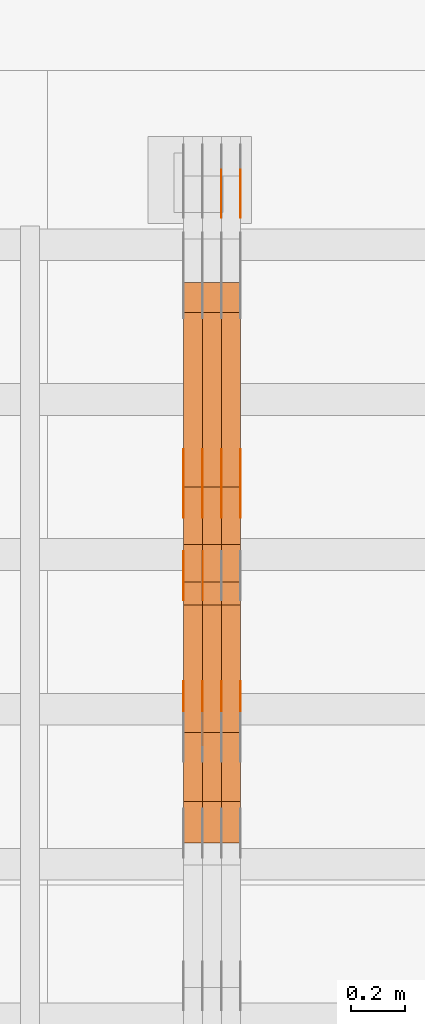
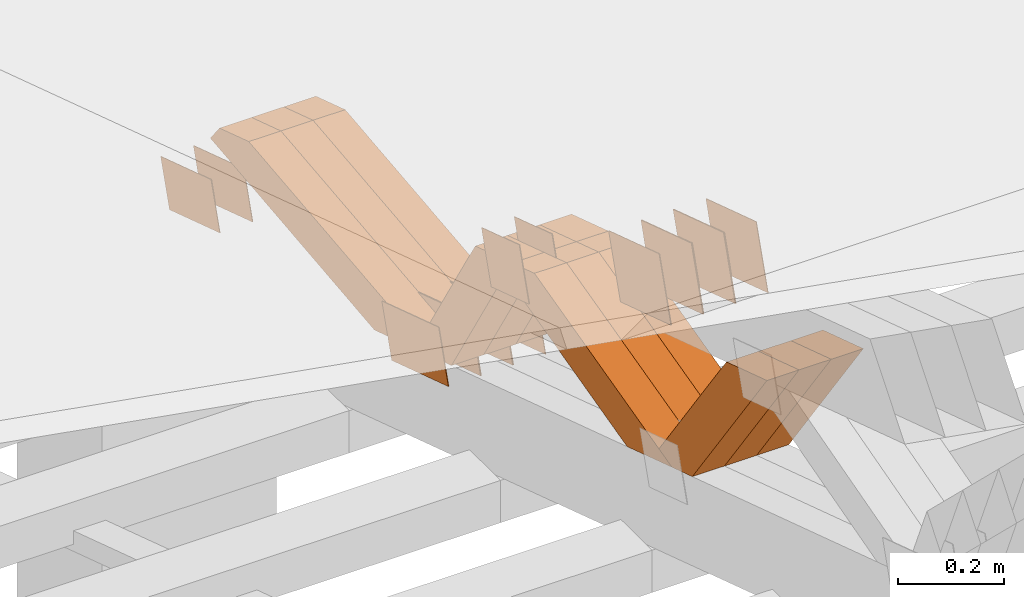
# One storey, part 202 of 385: 28 proxies.
"""IFC2X3 building model written with IfcOpenShell, lengths in millimetres."""

from ifc_helpers import new_model, entity, si_unit, converted_unit, derived_unit, direction, frame, origin, place, context, subcontext, project, spatial, polyline, outline, extrude, source, transform, mapped, material, type_object, type_shapes, element, save


model = new_model("IFC2X3")

# Units and contexts
model_context = context("Model", 3, precision=0.01, world=origin(), true_north=direction((6.12303176911189e-17, 1.0)))
body_context = subcontext(model_context, "Body", "Model", "MODEL_VIEW")
ifc_project = project(units=[si_unit("LENGTHUNIT", "METRE", prefix="MILLI"), si_unit("AREAUNIT", "SQUARE_METRE"), si_unit("VOLUMEUNIT", "CUBIC_METRE"), converted_unit("PLANEANGLEUNIT", "DEGREE", entity("IfcRatioMeasure", 0.0174532925199433), si_unit("PLANEANGLEUNIT", "RADIAN"), dimensions=[0, 0, 0, 0, 0, 0, 0]), si_unit("MASSUNIT", "GRAM", prefix="KILO"), derived_unit("MASSDENSITYUNIT", [(si_unit("MASSUNIT", "GRAM", prefix="KILO"), 1), (si_unit("LENGTHUNIT", "METRE"), -3)]), si_unit("TIMEUNIT", "SECOND"), si_unit("FREQUENCYUNIT", "HERTZ"), si_unit("THERMODYNAMICTEMPERATUREUNIT", "DEGREE_CELSIUS"), derived_unit("THERMALTRANSMITTANCEUNIT", [(si_unit("MASSUNIT", "GRAM", prefix="KILO"), 1), (si_unit("THERMODYNAMICTEMPERATUREUNIT", "KELVIN"), -1), (si_unit("TIMEUNIT", "SECOND"), -3)]), derived_unit("VOLUMETRICFLOWRATEUNIT", [(si_unit("LENGTHUNIT", "METRE"), 3), (si_unit("TIMEUNIT", "SECOND"), -1)]), si_unit("ELECTRICCURRENTUNIT", "AMPERE"), si_unit("ELECTRICVOLTAGEUNIT", "VOLT"), si_unit("POWERUNIT", "WATT"), si_unit("FORCEUNIT", "NEWTON", prefix="KILO"), si_unit("ILLUMINANCEUNIT", "LUX"), si_unit("LUMINOUSFLUXUNIT", "LUMEN"), si_unit("LUMINOUSINTENSITYUNIT", "CANDELA"), derived_unit("USERDEFINED", [(si_unit("MASSUNIT", "GRAM", prefix="KILO"), -1), (si_unit("LENGTHUNIT", "METRE"), -2), (si_unit("TIMEUNIT", "SECOND"), 3), (si_unit("LUMINOUSFLUXUNIT", "LUMEN"), 1)]), derived_unit("LINEARVELOCITYUNIT", [(si_unit("LENGTHUNIT", "METRE"), 1), (si_unit("TIMEUNIT", "SECOND"), -1)]), si_unit("PRESSUREUNIT", "PASCAL"), derived_unit("USERDEFINED", [(si_unit("LENGTHUNIT", "METRE"), -2), (si_unit("MASSUNIT", "GRAM", prefix="KILO"), 1), (si_unit("TIMEUNIT", "SECOND"), -2)])], contexts=[model_context])

# Site, building, storey
site_placement = place(None, origin())
site = spatial("IfcSite", under=ifc_project, at=site_placement, CompositionType="ELEMENT")
building_placement = place(site_placement, origin())
building = spatial("IfcBuilding", under=site, at=building_placement, CompositionType="ELEMENT")
storey_placement = place(building_placement, origin())
storey = spatial("IfcBuildingStorey", under=building, at=storey_placement, Name="Default", CompositionType="ELEMENT", Elevation=0.0)

# Proxies
ifc_material_1 = material(Name="IfcSurfaceStyle #137198")
building_element_proxy_type_1 = type_object("IfcBuildingElementProxyType", PredefinedType="NOTDEFINED", material=ifc_material_1)
shared_shape_1 = source(origin(), body_context, "Body", "SweptSolid", [
    extrude(outline(polyline([(-100.000024997547, -54.0000105875654), (100.000088940899, -54.0000105875654), (99.9999100805868, 54.0000105875654), (-99.9999740239394, 54.0000105875654), (-100.000024997547, -54.0000105875654)])), frame((100.000088940899, 54.0000474633838, 0.0), z_axis=(0.0, 0.0, 1.0), x_axis=(-1.0, 0.0, 0.0)), (0.0, 0.0, 1.0), 1.3),
])
type_shapes(building_element_proxy_type_1, [shared_shape_1])
proxy_1_placement = place(building_placement, frame((9386.29999999998, 26390.6212638563, 73.3227520411355), z_axis=(-1.0, 0.0, 0.0), x_axis=(0.0, -0.951056516295124, 0.309016994375039)))
element("IfcBuildingElementProxy", 1, at=proxy_1_placement, inside=storey, type_object=building_element_proxy_type_1, material=ifc_material_1, context=body_context, shape_type="MappedRepresentation", body=[
    mapped(shared_shape_1, transform((0.0, 0.0, 0.0), scale=1.0)),
])
ifc_material_2 = material(Name="IfcSurfaceStyle #137141")
building_element_proxy_type_2 = type_object("IfcBuildingElementProxyType", PredefinedType="NOTDEFINED", material=ifc_material_2)
shared_shape_2 = source(origin(), body_context, "Body", "SweptSolid", [
    extrude(outline(polyline([(-100.000024997547, -54.0000105875654), (100.000088940899, -54.0000105875654), (99.9999100805868, 54.0000105875654), (-99.9999740239394, 54.0000105875654), (-100.000024997547, -54.0000105875654)])), frame((100.000088940899, 54.0000474633838, 0.0), z_axis=(0.0, 0.0, 1.0), x_axis=(-1.0, 0.0, 0.0)), (0.0, 0.0, 1.0), 1.3),
])
type_shapes(building_element_proxy_type_2, [shared_shape_2])
proxy_2_placement = place(building_placement, frame((9315.0, 26390.6212638563, 73.3227520411355), z_axis=(-1.0, 0.0, 0.0), x_axis=(0.0, -0.951056516295124, 0.309016994375039)))
element("IfcBuildingElementProxy", 2, at=proxy_2_placement, inside=storey, type_object=building_element_proxy_type_2, material=ifc_material_2, context=body_context, shape_type="MappedRepresentation", body=[
    mapped(shared_shape_2, transform((0.0, 0.0, 0.0), scale=1.0)),
])
ifc_material_3 = material(Name="IfcSurfaceStyle #125342")
building_element_proxy_type_3 = type_object("IfcBuildingElementProxyType", PredefinedType="NOTDEFINED", material=ifc_material_3)
shared_shape_3 = source(origin(), body_context, "Body", "SweptSolid", [
    extrude(outline(polyline([(-75.0001163267648, -60.0000309352964), (75.0001029049313, -60.0000309352964), (75.0001068963143, 60.0000309352964), (-75.0000934744807, 60.0000309352964), (-75.0001163267648, -60.0000309352964)])), frame((75.0001143227305, 60.0000309352964, 0.0), z_axis=(0.0, 0.0, 1.0), x_axis=(-1.0, 0.0, 0.0)), (0.0, 0.0, 1.0), 1.29999999999999),
])
type_shapes(building_element_proxy_type_3, [shared_shape_3])
proxy_3_placement = place(building_placement, frame((9246.29999999998, 24935.0160969462, 827.753587802763), z_axis=(-1.0, 0.0, 0.0), x_axis=(0.0, -0.951056516295154, 0.309016994374948)))
element("IfcBuildingElementProxy", 3, at=proxy_3_placement, inside=storey, type_object=building_element_proxy_type_3, material=ifc_material_3, context=body_context, shape_type="MappedRepresentation", body=[
    mapped(shared_shape_3, transform((0.0, 0.0, 0.0), scale=1.0)),
])
ifc_material_4 = material(Name="IfcSurfaceStyle #125285")
building_element_proxy_type_4 = type_object("IfcBuildingElementProxyType", PredefinedType="NOTDEFINED", material=ifc_material_4)
shared_shape_4 = source(origin(), body_context, "Body", "SweptSolid", [
    extrude(outline(polyline([(-75.0001163267648, -60.0000309352964), (75.0001029049313, -60.0000309352964), (75.0001068963143, 60.0000309352964), (-75.0000934744807, 60.0000309352964), (-75.0001163267648, -60.0000309352964)])), frame((75.0001143227305, 60.0000309352964, 0.0), z_axis=(0.0, 0.0, 1.0), x_axis=(-1.0, 0.0, 0.0)), (0.0, 0.0, 1.0), 1.29999999999999),
])
type_shapes(building_element_proxy_type_4, [shared_shape_4])
proxy_4_placement = place(building_placement, frame((9175.0, 24935.0160969462, 827.753587802763), z_axis=(-1.0, 0.0, 0.0), x_axis=(0.0, -0.951056516295154, 0.309016994374948)))
element("IfcBuildingElementProxy", 4, at=proxy_4_placement, inside=storey, type_object=building_element_proxy_type_4, material=ifc_material_4, context=body_context, shape_type="MappedRepresentation", body=[
    mapped(shared_shape_4, transform((0.0, 0.0, 0.0), scale=1.0)),
])
ifc_material_5 = material(Name="IfcSurfaceStyle #125228")
building_element_proxy_type_5 = type_object("IfcBuildingElementProxyType", PredefinedType="NOTDEFINED", material=ifc_material_5)
shared_shape_5 = source(origin(), body_context, "Body", "SweptSolid", [
    extrude(outline(polyline([(-112.50003853564, -60.0000121429077), (112.50002982902, -60.0000121429077), (112.500043250865, 60.0000121429077), (-112.500034544245, 60.0000121429077), (-112.50003853564, -60.0000121429077)])), frame((112.500056021398, 60.0000121429077, 0.0), z_axis=(0.0, 0.0, 1.0), x_axis=(-1.0, 0.0, 0.0)), (0.0, 0.0, 1.0), 1.3),
])
type_shapes(building_element_proxy_type_5, [shared_shape_5])
proxy_5_placement = place(building_placement, frame((9386.29999999998, 25310.2182710495, 430.675738123044), z_axis=(-1.0, 0.0, 0.0), x_axis=(0.0, -0.951056516295124, 0.309016994375039)))
element("IfcBuildingElementProxy", 5, at=proxy_5_placement, inside=storey, type_object=building_element_proxy_type_5, material=ifc_material_5, context=body_context, shape_type="MappedRepresentation", body=[
    mapped(shared_shape_5, transform((0.0, 0.0, 0.0), scale=1.0)),
])
ifc_material_6 = material(Name="IfcSurfaceStyle #125171")
building_element_proxy_type_6 = type_object("IfcBuildingElementProxyType", PredefinedType="NOTDEFINED", material=ifc_material_6)
shared_shape_6 = source(origin(), body_context, "Body", "SweptSolid", [
    extrude(outline(polyline([(-112.50003853564, -60.0000121429077), (112.50002982902, -60.0000121429077), (112.500043250865, 60.0000121429077), (-112.500034544245, 60.0000121429077), (-112.50003853564, -60.0000121429077)])), frame((112.500056021398, 60.0000121429077, 0.0), z_axis=(0.0, 0.0, 1.0), x_axis=(-1.0, 0.0, 0.0)), (0.0, 0.0, 1.0), 1.3),
])
type_shapes(building_element_proxy_type_6, [shared_shape_6])
proxy_6_placement = place(building_placement, frame((9315.0, 25310.2182710495, 430.675738123044), z_axis=(-1.0, 0.0, 0.0), x_axis=(0.0, -0.951056516295124, 0.309016994375039)))
element("IfcBuildingElementProxy", 6, at=proxy_6_placement, inside=storey, type_object=building_element_proxy_type_6, material=ifc_material_6, context=body_context, shape_type="MappedRepresentation", body=[
    mapped(shared_shape_6, transform((0.0, 0.0, 0.0), scale=1.0)),
])
ifc_material_7 = material(Name="IfcSurfaceStyle #125114")
building_element_proxy_type_7 = type_object("IfcBuildingElementProxyType", PredefinedType="NOTDEFINED", material=ifc_material_7)
shared_shape_7 = source(origin(), body_context, "Body", "SweptSolid", [
    extrude(outline(polyline([(-112.50003853564, -60.0000121429077), (112.50002982902, -60.0000121429077), (112.500043250865, 60.0000121429077), (-112.500034544245, 60.0000121429077), (-112.50003853564, -60.0000121429077)])), frame((112.500056021398, 60.0000121429077, 0.0), z_axis=(0.0, 0.0, 1.0), x_axis=(-1.0, 0.0, 0.0)), (0.0, 0.0, 1.0), 1.3),
])
type_shapes(building_element_proxy_type_7, [shared_shape_7])
proxy_7_placement = place(building_placement, frame((9316.29999999998, 25310.2182710495, 430.675738123044), z_axis=(-1.0, 0.0, 0.0), x_axis=(0.0, -0.951056516295124, 0.309016994375039)))
element("IfcBuildingElementProxy", 7, at=proxy_7_placement, inside=storey, type_object=building_element_proxy_type_7, material=ifc_material_7, context=body_context, shape_type="MappedRepresentation", body=[
    mapped(shared_shape_7, transform((0.0, 0.0, 0.0), scale=1.0)),
])
ifc_material_8 = material(Name="IfcSurfaceStyle #125057")
building_element_proxy_type_8 = type_object("IfcBuildingElementProxyType", PredefinedType="NOTDEFINED", material=ifc_material_8)
shared_shape_8 = source(origin(), body_context, "Body", "SweptSolid", [
    extrude(outline(polyline([(-112.50003853564, -60.0000121429077), (112.50002982902, -60.0000121429077), (112.500043250865, 60.0000121429077), (-112.500034544245, 60.0000121429077), (-112.50003853564, -60.0000121429077)])), frame((112.500056021398, 60.0000121429077, 0.0), z_axis=(0.0, 0.0, 1.0), x_axis=(-1.0, 0.0, 0.0)), (0.0, 0.0, 1.0), 1.29999999999998),
])
type_shapes(building_element_proxy_type_8, [shared_shape_8])
proxy_8_placement = place(building_placement, frame((9245.0, 25310.2182710495, 430.675738123044), z_axis=(-1.0, 0.0, 0.0), x_axis=(0.0, -0.951056516295124, 0.309016994375039)))
element("IfcBuildingElementProxy", 8, at=proxy_8_placement, inside=storey, type_object=building_element_proxy_type_8, material=ifc_material_8, context=body_context, shape_type="MappedRepresentation", body=[
    mapped(shared_shape_8, transform((0.0, 0.0, 0.0), scale=1.0)),
])
ifc_material_9 = material(Name="IfcSurfaceStyle #125000")
building_element_proxy_type_9 = type_object("IfcBuildingElementProxyType", PredefinedType="NOTDEFINED", material=ifc_material_9)
shared_shape_9 = source(origin(), body_context, "Body", "SweptSolid", [
    extrude(outline(polyline([(-112.50003853564, -60.0000121429077), (112.50002982902, -60.0000121429077), (112.500043250865, 60.0000121429077), (-112.500034544245, 60.0000121429077), (-112.50003853564, -60.0000121429077)])), frame((112.500056021398, 60.0000121429077, 0.0), z_axis=(0.0, 0.0, 1.0), x_axis=(-1.0, 0.0, 0.0)), (0.0, 0.0, 1.0), 1.29999999999998),
])
type_shapes(building_element_proxy_type_9, [shared_shape_9])
proxy_9_placement = place(building_placement, frame((9246.29999999998, 25310.2182710495, 430.675738123044), z_axis=(-1.0, 0.0, 0.0), x_axis=(0.0, -0.951056516295124, 0.309016994375039)))
element("IfcBuildingElementProxy", 9, at=proxy_9_placement, inside=storey, type_object=building_element_proxy_type_9, material=ifc_material_9, context=body_context, shape_type="MappedRepresentation", body=[
    mapped(shared_shape_9, transform((0.0, 0.0, 0.0), scale=1.0)),
])
ifc_material_10 = material(Name="IfcSurfaceStyle #124943")
building_element_proxy_type_10 = type_object("IfcBuildingElementProxyType", PredefinedType="NOTDEFINED", material=ifc_material_10)
shared_shape_10 = source(origin(), body_context, "Body", "SweptSolid", [
    extrude(outline(polyline([(-112.50003853564, -60.0000121429077), (112.50002982902, -60.0000121429077), (112.500043250865, 60.0000121429077), (-112.500034544245, 60.0000121429077), (-112.50003853564, -60.0000121429077)])), frame((112.500056021398, 60.0000121429077, 0.0), z_axis=(0.0, 0.0, 1.0), x_axis=(-1.0, 0.0, 0.0)), (0.0, 0.0, 1.0), 1.29999999999999),
])
type_shapes(building_element_proxy_type_10, [shared_shape_10])
proxy_10_placement = place(building_placement, frame((9175.0, 25310.2182710495, 430.675738123044), z_axis=(-1.0, 0.0, 0.0), x_axis=(0.0, -0.951056516295124, 0.309016994375039)))
element("IfcBuildingElementProxy", 10, at=proxy_10_placement, inside=storey, type_object=building_element_proxy_type_10, material=ifc_material_10, context=body_context, shape_type="MappedRepresentation", body=[
    mapped(shared_shape_10, transform((0.0, 0.0, 0.0), scale=1.0)),
])
ifc_material_11 = material(Name="IfcSurfaceStyle #123176")
building_element_proxy_type_11 = type_object("IfcBuildingElementProxyType", PredefinedType="NOTDEFINED", material=ifc_material_11)
shared_shape_11 = source(origin(), body_context, "Body", "SweptSolid", [
    extrude(outline(polyline([(-100.000009625089, -72.0000630699202), (100.000090167682, -72.0000630699202), (100.000009625089, 72.0000630699202), (-100.000090167682, 72.0000630699202), (-100.000009625089, -72.0000630699202)])), frame((100.000090167682, 72.0000630699202, 0.0), z_axis=(0.0, 0.0, 1.0), x_axis=(-1.0, 0.0, 0.0)), (0.0, 0.0, 1.0), 1.3),
])
type_shapes(building_element_proxy_type_11, [shared_shape_11])
proxy_11_placement = place(building_placement, frame((9386.29999999998, 24447.7695802369, 1088.58717039832), z_axis=(-1.0, 0.0, 0.0), x_axis=(0.0, -0.951056516295154, 0.309016994374948)))
element("IfcBuildingElementProxy", 11, at=proxy_11_placement, inside=storey, type_object=building_element_proxy_type_11, material=ifc_material_11, context=body_context, shape_type="MappedRepresentation", body=[
    mapped(shared_shape_11, transform((0.0, 0.0, 0.0), scale=1.0)),
])
ifc_material_12 = material(Name="IfcSurfaceStyle #123119")
building_element_proxy_type_12 = type_object("IfcBuildingElementProxyType", PredefinedType="NOTDEFINED", material=ifc_material_12)
shared_shape_12 = source(origin(), body_context, "Body", "SweptSolid", [
    extrude(outline(polyline([(-100.000009625089, -72.0000630699202), (100.000090167682, -72.0000630699202), (100.000009625089, 72.0000630699202), (-100.000090167682, 72.0000630699202), (-100.000009625089, -72.0000630699202)])), frame((100.000090167682, 72.0000630699202, 0.0), z_axis=(0.0, 0.0, 1.0), x_axis=(-1.0, 0.0, 0.0)), (0.0, 0.0, 1.0), 1.3),
])
type_shapes(building_element_proxy_type_12, [shared_shape_12])
proxy_12_placement = place(building_placement, frame((9315.0, 24447.7695802369, 1088.58717039832), z_axis=(-1.0, 0.0, 0.0), x_axis=(0.0, -0.951056516295154, 0.309016994374948)))
element("IfcBuildingElementProxy", 12, at=proxy_12_placement, inside=storey, type_object=building_element_proxy_type_12, material=ifc_material_12, context=body_context, shape_type="MappedRepresentation", body=[
    mapped(shared_shape_12, transform((0.0, 0.0, 0.0), scale=1.0)),
])
ifc_material_13 = material(Name="IfcSurfaceStyle #123062")
building_element_proxy_type_13 = type_object("IfcBuildingElementProxyType", PredefinedType="NOTDEFINED", material=ifc_material_13)
shared_shape_13 = source(origin(), body_context, "Body", "SweptSolid", [
    extrude(outline(polyline([(-100.000009625089, -72.0000630699202), (100.000090167682, -72.0000630699202), (100.000009625089, 72.0000630699202), (-100.000090167682, 72.0000630699202), (-100.000009625089, -72.0000630699202)])), frame((100.000090167682, 72.0000630699202, 0.0), z_axis=(0.0, 0.0, 1.0), x_axis=(-1.0, 0.0, 0.0)), (0.0, 0.0, 1.0), 1.3),
])
type_shapes(building_element_proxy_type_13, [shared_shape_13])
proxy_13_placement = place(building_placement, frame((9316.29999999998, 24447.7695802369, 1088.58717039832), z_axis=(-1.0, 0.0, 0.0), x_axis=(0.0, -0.951056516295154, 0.309016994374948)))
element("IfcBuildingElementProxy", 13, at=proxy_13_placement, inside=storey, type_object=building_element_proxy_type_13, material=ifc_material_13, context=body_context, shape_type="MappedRepresentation", body=[
    mapped(shared_shape_13, transform((0.0, 0.0, 0.0), scale=1.0)),
])
ifc_material_14 = material(Name="IfcSurfaceStyle #123005")
building_element_proxy_type_14 = type_object("IfcBuildingElementProxyType", PredefinedType="NOTDEFINED", material=ifc_material_14)
shared_shape_14 = source(origin(), body_context, "Body", "SweptSolid", [
    extrude(outline(polyline([(-100.000009625089, -72.0000630699202), (100.000090167682, -72.0000630699202), (100.000009625089, 72.0000630699202), (-100.000090167682, 72.0000630699202), (-100.000009625089, -72.0000630699202)])), frame((100.000090167682, 72.0000630699202, 0.0), z_axis=(0.0, 0.0, 1.0), x_axis=(-1.0, 0.0, 0.0)), (0.0, 0.0, 1.0), 1.29999999999998),
])
type_shapes(building_element_proxy_type_14, [shared_shape_14])
proxy_14_placement = place(building_placement, frame((9245.0, 24447.7695802369, 1088.58717039832), z_axis=(-1.0, 0.0, 0.0), x_axis=(0.0, -0.951056516295154, 0.309016994374948)))
element("IfcBuildingElementProxy", 14, at=proxy_14_placement, inside=storey, type_object=building_element_proxy_type_14, material=ifc_material_14, context=body_context, shape_type="MappedRepresentation", body=[
    mapped(shared_shape_14, transform((0.0, 0.0, 0.0), scale=1.0)),
])
ifc_material_15 = material(Name="IfcSurfaceStyle #122948")
building_element_proxy_type_15 = type_object("IfcBuildingElementProxyType", PredefinedType="NOTDEFINED", material=ifc_material_15)
shared_shape_15 = source(origin(), body_context, "Body", "SweptSolid", [
    extrude(outline(polyline([(-100.000009625089, -72.0000630699202), (100.000090167682, -72.0000630699202), (100.000009625089, 72.0000630699202), (-100.000090167682, 72.0000630699202), (-100.000009625089, -72.0000630699202)])), frame((100.000090167682, 72.0000630699202, 0.0), z_axis=(0.0, 0.0, 1.0), x_axis=(-1.0, 0.0, 0.0)), (0.0, 0.0, 1.0), 1.29999999999998),
])
type_shapes(building_element_proxy_type_15, [shared_shape_15])
proxy_15_placement = place(building_placement, frame((9246.29999999998, 24447.7695802369, 1088.58717039832), z_axis=(-1.0, 0.0, 0.0), x_axis=(0.0, -0.951056516295154, 0.309016994374948)))
element("IfcBuildingElementProxy", 15, at=proxy_15_placement, inside=storey, type_object=building_element_proxy_type_15, material=ifc_material_15, context=body_context, shape_type="MappedRepresentation", body=[
    mapped(shared_shape_15, transform((0.0, 0.0, 0.0), scale=1.0)),
])
ifc_material_16 = material(Name="IfcSurfaceStyle #122891")
building_element_proxy_type_16 = type_object("IfcBuildingElementProxyType", PredefinedType="NOTDEFINED", material=ifc_material_16)
shared_shape_16 = source(origin(), body_context, "Body", "SweptSolid", [
    extrude(outline(polyline([(-100.000009625089, -72.0000630699202), (100.000090167682, -72.0000630699202), (100.000009625089, 72.0000630699202), (-100.000090167682, 72.0000630699202), (-100.000009625089, -72.0000630699202)])), frame((100.000090167682, 72.0000630699202, 0.0), z_axis=(0.0, 0.0, 1.0), x_axis=(-1.0, 0.0, 0.0)), (0.0, 0.0, 1.0), 1.29999999999999),
])
type_shapes(building_element_proxy_type_16, [shared_shape_16])
proxy_16_placement = place(building_placement, frame((9175.0, 24447.7695802369, 1088.58717039832), z_axis=(-1.0, 0.0, 0.0), x_axis=(0.0, -0.951056516295154, 0.309016994374948)))
element("IfcBuildingElementProxy", 16, at=proxy_16_placement, inside=storey, type_object=building_element_proxy_type_16, material=ifc_material_16, context=body_context, shape_type="MappedRepresentation", body=[
    mapped(shared_shape_16, transform((0.0, 0.0, 0.0), scale=1.0)),
])
ifc_material_17 = material(Name="IfcSurfaceStyle #113978")
building_element_proxy_type_17 = type_object("IfcBuildingElementProxyType", Name="T1-W24 113976", PredefinedType="NOTDEFINED", material=ifc_material_17)
shared_shape_17 = source(origin(), body_context, "Body", "SweptSolid", [
    extrude(outline(polyline([(-215.642157779899, -47.4998772343114), (220.829928576248, -47.4998772343114), (202.182343865616, 6.34871490324596e-05), (137.545638852774, 47.4998454907369), (-344.915753514738, 47.4998454907369), (-215.642157779899, -47.4998772343114)])), frame((220.830079609702, 47.500154567531, 0.0), z_axis=(0.0, 0.0, 1.0), x_axis=(-1.0, 0.0, 0.0)), (0.0, 0.0, 1.0), 70.0),
])
type_shapes(building_element_proxy_type_17, [shared_shape_17])
proxy_17_placement = place(building_placement, frame((9385.0, 24227.7045444998, 781.019082122604), z_axis=(-1.0, 0.0, 0.0), x_axis=(0.0, -0.583381854128324, 0.812198012970851)))
element("IfcBuildingElementProxy", 17, at=proxy_17_placement, inside=storey, type_object=building_element_proxy_type_17, material=ifc_material_17, Name="T1-W24", context=body_context, shape_type="MappedRepresentation", body=[
    mapped(shared_shape_17, transform((0.0, 0.0, 0.0), scale=1.0)),
])
ifc_material_18 = material(Name="IfcSurfaceStyle #113912")
building_element_proxy_type_18 = type_object("IfcBuildingElementProxyType", Name="T1-W24 113910", PredefinedType="NOTDEFINED", material=ifc_material_18)
shared_shape_18 = source(origin(), body_context, "Body", "SweptSolid", [
    extrude(outline(polyline([(-215.642157779899, -47.4998772343114), (220.829928576248, -47.4998772343114), (202.182343865616, 6.34871490324596e-05), (137.545638852774, 47.4998454907369), (-344.915753514738, 47.4998454907369), (-215.642157779899, -47.4998772343114)])), frame((220.830079609702, 47.500154567531, 0.0), z_axis=(0.0, 0.0, 1.0), x_axis=(-1.0, 0.0, 0.0)), (0.0, 0.0, 1.0), 70.0),
])
type_shapes(building_element_proxy_type_18, [shared_shape_18])
proxy_18_placement = place(building_placement, frame((9315.0, 24227.7045444998, 781.019082122604), z_axis=(-1.0, 0.0, 0.0), x_axis=(0.0, -0.583381854128324, 0.812198012970851)))
element("IfcBuildingElementProxy", 18, at=proxy_18_placement, inside=storey, type_object=building_element_proxy_type_18, material=ifc_material_18, Name="T1-W24", context=body_context, shape_type="MappedRepresentation", body=[
    mapped(shared_shape_18, transform((0.0, 0.0, 0.0), scale=1.0)),
])
ifc_material_19 = material(Name="IfcSurfaceStyle #113846")
building_element_proxy_type_19 = type_object("IfcBuildingElementProxyType", Name="T1-W24 113844", PredefinedType="NOTDEFINED", material=ifc_material_19)
shared_shape_19 = source(origin(), body_context, "Body", "SweptSolid", [
    extrude(outline(polyline([(-215.642157779899, -47.4998772343114), (220.829928576248, -47.4998772343114), (202.182343865616, 6.34871490324596e-05), (137.545638852774, 47.4998454907369), (-344.915753514738, 47.4998454907369), (-215.642157779899, -47.4998772343114)])), frame((220.830079609702, 47.500154567531, 0.0), z_axis=(0.0, 0.0, 1.0), x_axis=(-1.0, 0.0, 0.0)), (0.0, 0.0, 1.0), 70.0),
])
type_shapes(building_element_proxy_type_19, [shared_shape_19])
proxy_19_placement = place(building_placement, frame((9245.0, 24227.7045444998, 781.019082122604), z_axis=(-1.0, 0.0, 0.0), x_axis=(0.0, -0.583381854128324, 0.812198012970851)))
element("IfcBuildingElementProxy", 19, at=proxy_19_placement, inside=storey, type_object=building_element_proxy_type_19, material=ifc_material_19, Name="T1-W24", context=body_context, shape_type="MappedRepresentation", body=[
    mapped(shared_shape_19, transform((0.0, 0.0, 0.0), scale=1.0)),
])
ifc_material_20 = material(Name="IfcSurfaceStyle #113582")
building_element_proxy_type_20 = type_object("IfcBuildingElementProxyType", Name="T1-W13 113580", PredefinedType="NOTDEFINED", material=ifc_material_20)
shared_shape_20 = source(origin(), body_context, "Body", "SweptSolid", [
    extrude(outline(polyline([(-384.339592151497, -47.5000055308246), (150.996422207105, -47.5000055308247), (226.265349299398, -4.29484466835994e-05), (240.878612116891, 47.500027005048), (-233.800791471897, 47.500027005048), (-384.339592151497, -47.5000055308246)])), frame((240.878612116891, 47.500027005048, 0.0), z_axis=(0.0, 0.0, 1.0), x_axis=(-1.0, 0.0, 0.0)), (0.0, 0.0, 1.0), 70.0),
])
type_shapes(building_element_proxy_type_20, [shared_shape_20])
proxy_20_placement = place(building_placement, frame((9385.0, 24884.765625, 885.749145507813), z_axis=(-1.0, 0.0, 0.0), x_axis=(0.0, -0.969210894563555, -0.246232089418326)))
element("IfcBuildingElementProxy", 20, at=proxy_20_placement, inside=storey, type_object=building_element_proxy_type_20, material=ifc_material_20, Name="T1-W13", context=body_context, shape_type="MappedRepresentation", body=[
    mapped(shared_shape_20, transform((0.0, 0.0, 0.0), scale=1.0)),
])
ifc_material_21 = material(Name="IfcSurfaceStyle #113516")
building_element_proxy_type_21 = type_object("IfcBuildingElementProxyType", Name="T1-W13 113514", PredefinedType="NOTDEFINED", material=ifc_material_21)
shared_shape_21 = source(origin(), body_context, "Body", "SweptSolid", [
    extrude(outline(polyline([(-384.339592151497, -47.5000055308246), (150.996422207105, -47.5000055308247), (226.265349299398, -4.29484466835994e-05), (240.878612116891, 47.500027005048), (-233.800791471897, 47.500027005048), (-384.339592151497, -47.5000055308246)])), frame((240.878612116891, 47.500027005048, 0.0), z_axis=(0.0, 0.0, 1.0), x_axis=(-1.0, 0.0, 0.0)), (0.0, 0.0, 1.0), 70.0),
])
type_shapes(building_element_proxy_type_21, [shared_shape_21])
proxy_21_placement = place(building_placement, frame((9315.0, 24884.765625, 885.749145507813), z_axis=(-1.0, 0.0, 0.0), x_axis=(0.0, -0.969210894563555, -0.246232089418326)))
element("IfcBuildingElementProxy", 21, at=proxy_21_placement, inside=storey, type_object=building_element_proxy_type_21, material=ifc_material_21, Name="T1-W13", context=body_context, shape_type="MappedRepresentation", body=[
    mapped(shared_shape_21, transform((0.0, 0.0, 0.0), scale=1.0)),
])
ifc_material_22 = material(Name="IfcSurfaceStyle #113450")
building_element_proxy_type_22 = type_object("IfcBuildingElementProxyType", Name="T1-W13 113448", PredefinedType="NOTDEFINED", material=ifc_material_22)
shared_shape_22 = source(origin(), body_context, "Body", "SweptSolid", [
    extrude(outline(polyline([(-384.339592151497, -47.5000055308246), (150.996422207105, -47.5000055308247), (226.265349299398, -4.29484466835994e-05), (240.878612116891, 47.500027005048), (-233.800791471897, 47.500027005048), (-384.339592151497, -47.5000055308246)])), frame((240.878612116891, 47.500027005048, 0.0), z_axis=(0.0, 0.0, 1.0), x_axis=(-1.0, 0.0, 0.0)), (0.0, 0.0, 1.0), 70.0),
])
type_shapes(building_element_proxy_type_22, [shared_shape_22])
proxy_22_placement = place(building_placement, frame((9245.0, 24884.765625, 885.749145507813), z_axis=(-1.0, 0.0, 0.0), x_axis=(0.0, -0.969210894563555, -0.246232089418326)))
element("IfcBuildingElementProxy", 22, at=proxy_22_placement, inside=storey, type_object=building_element_proxy_type_22, material=ifc_material_22, Name="T1-W13", context=body_context, shape_type="MappedRepresentation", body=[
    mapped(shared_shape_22, transform((0.0, 0.0, 0.0), scale=1.0)),
])
ifc_material_23 = material(Name="IfcSurfaceStyle #113186")
building_element_proxy_type_23 = type_object("IfcBuildingElementProxyType", Name="T1-W31 113184", PredefinedType="NOTDEFINED", material=ifc_material_23)
shared_shape_23 = source(origin(), body_context, "Body", "SweptSolid", [
    extrude(outline(polyline([(-201.245318299844, -47.5000121670808), (204.413774229459, -47.5000121670808), (182.034306640891, 5.35692244583164e-05), (126.70380769348, 47.4999853824686), (-311.906570263987, 47.4999853824686), (-201.245318299844, -47.5000121670808)])), frame((204.413774229459, 47.5002684334588, 0.0), z_axis=(0.0, 0.0, 1.0), x_axis=(-1.0, 0.0, 0.0)), (0.0, 0.0, 1.0), 70.0),
])
type_shapes(building_element_proxy_type_23, [shared_shape_23])
proxy_23_placement = place(building_placement, frame((9385.0, 25127.5652647985, 487.27008059185), z_axis=(-1.0, 0.0, 0.0), x_axis=(0.0, -0.520333970303023, 0.853962855953755)))
element("IfcBuildingElementProxy", 23, at=proxy_23_placement, inside=storey, type_object=building_element_proxy_type_23, material=ifc_material_23, Name="T1-W31", context=body_context, shape_type="MappedRepresentation", body=[
    mapped(shared_shape_23, transform((0.0, 0.0, 0.0), scale=1.0)),
])
ifc_material_24 = material(Name="IfcSurfaceStyle #113120")
building_element_proxy_type_24 = type_object("IfcBuildingElementProxyType", Name="T1-W31 113118", PredefinedType="NOTDEFINED", material=ifc_material_24)
shared_shape_24 = source(origin(), body_context, "Body", "SweptSolid", [
    extrude(outline(polyline([(-201.245318299844, -47.5000121670808), (204.413774229459, -47.5000121670808), (182.034306640891, 5.35692244583164e-05), (126.70380769348, 47.4999853824686), (-311.906570263987, 47.4999853824686), (-201.245318299844, -47.5000121670808)])), frame((204.413774229459, 47.5002684334588, 0.0), z_axis=(0.0, 0.0, 1.0), x_axis=(-1.0, 0.0, 0.0)), (0.0, 0.0, 1.0), 70.0),
])
type_shapes(building_element_proxy_type_24, [shared_shape_24])
proxy_24_placement = place(building_placement, frame((9315.0, 25127.5652647985, 487.27008059185), z_axis=(-1.0, 0.0, 0.0), x_axis=(0.0, -0.520333970303023, 0.853962855953755)))
element("IfcBuildingElementProxy", 24, at=proxy_24_placement, inside=storey, type_object=building_element_proxy_type_24, material=ifc_material_24, Name="T1-W31", context=body_context, shape_type="MappedRepresentation", body=[
    mapped(shared_shape_24, transform((0.0, 0.0, 0.0), scale=1.0)),
])
ifc_material_25 = material(Name="IfcSurfaceStyle #113054")
building_element_proxy_type_25 = type_object("IfcBuildingElementProxyType", Name="T1-W31 113052", PredefinedType="NOTDEFINED", material=ifc_material_25)
shared_shape_25 = source(origin(), body_context, "Body", "SweptSolid", [
    extrude(outline(polyline([(-201.245318299844, -47.5000121670808), (204.413774229459, -47.5000121670808), (182.034306640891, 5.35692244583164e-05), (126.70380769348, 47.4999853824686), (-311.906570263987, 47.4999853824686), (-201.245318299844, -47.5000121670808)])), frame((204.413774229459, 47.5002684334588, 0.0), z_axis=(0.0, 0.0, 1.0), x_axis=(-1.0, 0.0, 0.0)), (0.0, 0.0, 1.0), 70.0),
])
type_shapes(building_element_proxy_type_25, [shared_shape_25])
proxy_25_placement = place(building_placement, frame((9245.0, 25127.5652647985, 487.27008059185), z_axis=(-1.0, 0.0, 0.0), x_axis=(0.0, -0.520333970303023, 0.853962855953755)))
element("IfcBuildingElementProxy", 25, at=proxy_25_placement, inside=storey, type_object=building_element_proxy_type_25, material=ifc_material_25, Name="T1-W31", context=body_context, shape_type="MappedRepresentation", body=[
    mapped(shared_shape_25, transform((0.0, 0.0, 0.0), scale=1.0)),
])
ifc_material_26 = material(Name="IfcSurfaceStyle #112790")
building_element_proxy_type_26 = type_object("IfcBuildingElementProxyType", Name="T1-W4 112788", PredefinedType="NOTDEFINED", material=ifc_material_26)
shared_shape_26 = source(origin(), body_context, "Body", "SweptSolid", [
    extrude(outline(polyline([(-510.077325435179, -47.4999981284922), (188.854793418912, -47.4999981284922), (294.906688207675, 1.67015383116809e-05), (324.289382923648, 47.499989777723), (-297.973539115057, 47.4999897777231), (-510.077325435179, -47.4999981284922)])), frame((324.289382923648, 47.5000278316275, 0.0), z_axis=(0.0, 0.0, 1.0), x_axis=(-1.0, 0.0, 0.0)), (0.0, 0.0, 1.0), 70.0),
])
type_shapes(building_element_proxy_type_26, [shared_shape_26])
proxy_26_placement = place(building_placement, frame((9385.0, 25996.2241251556, 525.69905884318), z_axis=(-1.0, 0.0, 0.0), x_axis=(0.0, -0.994287125203057, -0.106738524701444)))
element("IfcBuildingElementProxy", 26, at=proxy_26_placement, inside=storey, type_object=building_element_proxy_type_26, material=ifc_material_26, Name="T1-W4", context=body_context, shape_type="MappedRepresentation", body=[
    mapped(shared_shape_26, transform((0.0, 0.0, 0.0), scale=1.0)),
])
ifc_material_27 = material(Name="IfcSurfaceStyle #112724")
building_element_proxy_type_27 = type_object("IfcBuildingElementProxyType", Name="T1-W4 112722", PredefinedType="NOTDEFINED", material=ifc_material_27)
shared_shape_27 = source(origin(), body_context, "Body", "SweptSolid", [
    extrude(outline(polyline([(-510.077325435179, -47.4999981284922), (188.854793418912, -47.4999981284922), (294.906688207675, 1.67015383116809e-05), (324.289382923648, 47.499989777723), (-297.973539115057, 47.4999897777231), (-510.077325435179, -47.4999981284922)])), frame((324.289382923648, 47.5000278316275, 0.0), z_axis=(0.0, 0.0, 1.0), x_axis=(-1.0, 0.0, 0.0)), (0.0, 0.0, 1.0), 70.0),
])
type_shapes(building_element_proxy_type_27, [shared_shape_27])
proxy_27_placement = place(building_placement, frame((9315.0, 25996.2241251556, 525.69905884318), z_axis=(-1.0, 0.0, 0.0), x_axis=(0.0, -0.994287125203057, -0.106738524701444)))
element("IfcBuildingElementProxy", 27, at=proxy_27_placement, inside=storey, type_object=building_element_proxy_type_27, material=ifc_material_27, Name="T1-W4", context=body_context, shape_type="MappedRepresentation", body=[
    mapped(shared_shape_27, transform((0.0, 0.0, 0.0), scale=1.0)),
])
ifc_material_28 = material(Name="IfcSurfaceStyle #112658")
building_element_proxy_type_28 = type_object("IfcBuildingElementProxyType", Name="T1-W4 112656", PredefinedType="NOTDEFINED", material=ifc_material_28)
shared_shape_28 = source(origin(), body_context, "Body", "SweptSolid", [
    extrude(outline(polyline([(-510.077325435179, -47.4999981284922), (188.854793418912, -47.4999981284922), (294.906688207675, 1.67015383116809e-05), (324.289382923648, 47.499989777723), (-297.973539115057, 47.4999897777231), (-510.077325435179, -47.4999981284922)])), frame((324.289382923648, 47.5000278316275, 0.0), z_axis=(0.0, 0.0, 1.0), x_axis=(-1.0, 0.0, 0.0)), (0.0, 0.0, 1.0), 70.0),
])
type_shapes(building_element_proxy_type_28, [shared_shape_28])
proxy_28_placement = place(building_placement, frame((9245.0, 25996.2241251556, 525.69905884318), z_axis=(-1.0, 0.0, 0.0), x_axis=(0.0, -0.994287125203057, -0.106738524701444)))
element("IfcBuildingElementProxy", 28, at=proxy_28_placement, inside=storey, type_object=building_element_proxy_type_28, material=ifc_material_28, Name="T1-W4", context=body_context, shape_type="MappedRepresentation", body=[
    mapped(shared_shape_28, transform((0.0, 0.0, 0.0), scale=1.0)),
])

save(model, "model.ifc")
